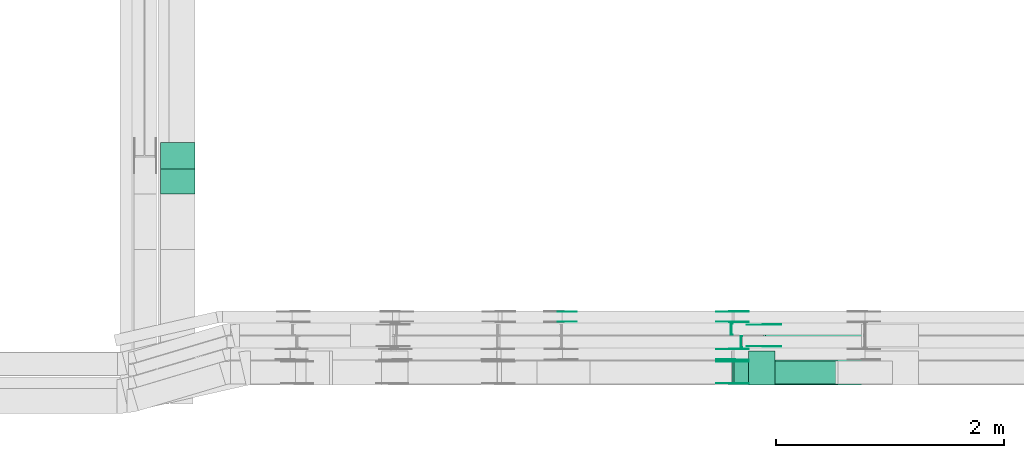
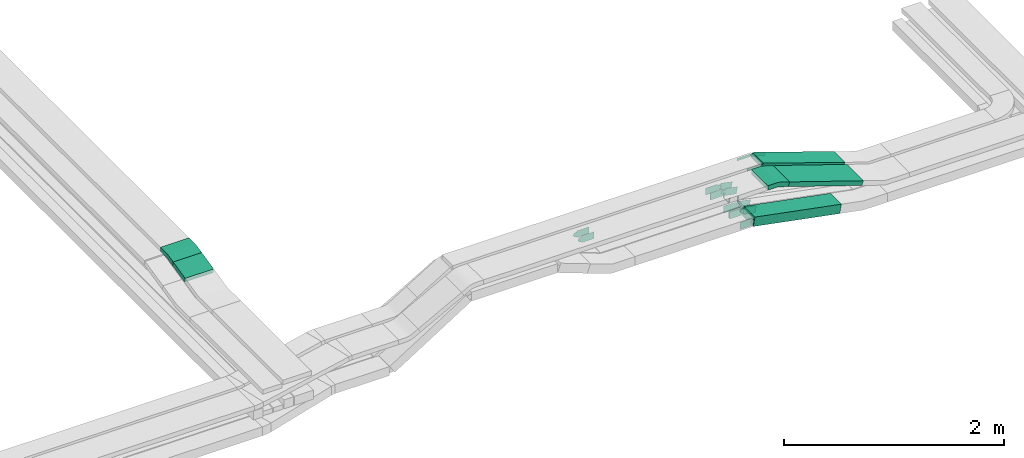
# One storey, part 27 of 31: 22 flow fittings, 4 flow segments.
"""IFC2X3 building model written with IfcOpenShell, lengths in millimetres."""

from ifc_helpers import new_model, entity, si_unit, converted_unit, derived_unit, direction, frame, frame_2d, origin, origin_2d_with_axis, place, context, subcontext, project, spatial, polyline, circle_curve, parameter, trimmed, segment, composite_curve, rectangle, outline, extrude, faceted_brep, source, transform, mapped, material, type_object, type_shapes, element, save


model = new_model("IFC2X3")

# Units and contexts
model_context = context("Model", 3, precision=0.01, world=origin(), true_north=direction((6.12303176911189e-17, 1.0)))
body_context = subcontext(model_context, "Body", "Model", "MODEL_VIEW")
ifc_project = project(units=[si_unit("LENGTHUNIT", "METRE", prefix="MILLI"), si_unit("AREAUNIT", "SQUARE_METRE"), si_unit("VOLUMEUNIT", "CUBIC_METRE"), converted_unit("PLANEANGLEUNIT", "DEGREE", entity("IfcRatioMeasure", 0.0174532925199433), si_unit("PLANEANGLEUNIT", "RADIAN"), dimensions=[0, 0, 0, 0, 0, 0, 0]), si_unit("MASSUNIT", "GRAM", prefix="KILO"), derived_unit("MASSDENSITYUNIT", [(si_unit("MASSUNIT", "GRAM", prefix="KILO"), 1), (si_unit("LENGTHUNIT", "METRE"), -3)]), derived_unit("MOMENTOFINERTIAUNIT", [(si_unit("LENGTHUNIT", "METRE"), 4)]), si_unit("TIMEUNIT", "SECOND"), si_unit("FREQUENCYUNIT", "HERTZ"), si_unit("THERMODYNAMICTEMPERATUREUNIT", "DEGREE_CELSIUS"), derived_unit("THERMALTRANSMITTANCEUNIT", [(si_unit("MASSUNIT", "GRAM", prefix="KILO"), 1), (si_unit("THERMODYNAMICTEMPERATUREUNIT", "KELVIN"), -1), (si_unit("TIMEUNIT", "SECOND"), -3)]), derived_unit("VOLUMETRICFLOWRATEUNIT", [(si_unit("LENGTHUNIT", "METRE"), 3), (si_unit("TIMEUNIT", "SECOND"), -1)]), derived_unit("MASSFLOWRATEUNIT", [(si_unit("MASSUNIT", "GRAM", prefix="KILO"), 1), (si_unit("TIMEUNIT", "SECOND"), -1)]), derived_unit("ROTATIONALFREQUENCYUNIT", [(si_unit("TIMEUNIT", "SECOND"), -1)]), si_unit("ELECTRICCURRENTUNIT", "AMPERE"), si_unit("ELECTRICVOLTAGEUNIT", "VOLT"), si_unit("POWERUNIT", "WATT"), si_unit("FORCEUNIT", "NEWTON", prefix="KILO"), si_unit("ILLUMINANCEUNIT", "LUX"), si_unit("LUMINOUSFLUXUNIT", "LUMEN"), si_unit("LUMINOUSINTENSITYUNIT", "CANDELA"), derived_unit("USERDEFINED", [(si_unit("MASSUNIT", "GRAM", prefix="KILO"), -1), (si_unit("LENGTHUNIT", "METRE"), -2), (si_unit("TIMEUNIT", "SECOND"), 3), (si_unit("LUMINOUSFLUXUNIT", "LUMEN"), 1)]), derived_unit("LINEARVELOCITYUNIT", [(si_unit("LENGTHUNIT", "METRE"), 1), (si_unit("TIMEUNIT", "SECOND"), -1)]), si_unit("PRESSUREUNIT", "PASCAL"), derived_unit("USERDEFINED", [(si_unit("LENGTHUNIT", "METRE"), -2), (si_unit("MASSUNIT", "GRAM", prefix="KILO"), 1), (si_unit("TIMEUNIT", "SECOND"), -2)]), derived_unit("LINEARFORCEUNIT", [(si_unit("MASSUNIT", "GRAM", prefix="KILO"), 1), (si_unit("LENGTHUNIT", "METRE"), 1), (si_unit("TIMEUNIT", "SECOND"), -2), (si_unit("LENGTHUNIT", "METRE"), -1)]), derived_unit("PLANARFORCEUNIT", [(si_unit("MASSUNIT", "GRAM", prefix="KILO"), 1), (si_unit("LENGTHUNIT", "METRE"), 1), (si_unit("TIMEUNIT", "SECOND"), -2), (si_unit("LENGTHUNIT", "METRE"), -2)])], contexts=[model_context])

# Site, building, storey
site_placement = place(None, frame((0.0, -0.00077364408347762, 0.0)))
site = spatial("IfcSite", under=ifc_project, at=site_placement, CompositionType="ELEMENT")
building_placement = place(site_placement, origin())
building = spatial("IfcBuilding", under=site, at=building_placement, CompositionType="ELEMENT")
storey_placement = place(building_placement, frame((0.0, 0.0, 15900.0)))
storey = spatial("IfcBuildingStorey", under=building, at=storey_placement, CompositionType="ELEMENT", Elevation=15900.0)

# Flow segments
cable_carrier_segment_type = type_object("IfcCableCarrierSegmentType", PredefinedType="CABLETRAYSEGMENT")
flow_segment_1_placement = place(storey_placement, frame((60480.8175590596, 10142.2365684485, 2935.93007796764)))
element("IfcFlowSegment", 1, at=flow_segment_1_placement, inside=storey, type_object=cable_carrier_segment_type, context=body_context, shape_type="SweptSolid", body=[
    extrude(rectangle(XDim=49.999999999999, YDim=224.379471632193, at=frame_2d((1.05870867628255e-12, -2.39808173319034e-13), x_axis=(0.0, 1.0))), frame((0.0, 114.940729492026, 49.171043083638), z_axis=(1.0, 0.0, 0.0), x_axis=(0.0, 0.975283876332618, 0.220955562422907)), (0.0, 0.0, 1.0), 300.000000000001),
])
flow_segment_2_placement = place(storey_placement, frame((65492.2607911448, 8474.9658623949, 2643.47474906301)))
element("IfcFlowSegment", 2, at=flow_segment_2_placement, inside=storey, type_object=cable_carrier_segment_type, context=body_context, shape_type="SweptSolid", body=[
    extrude(rectangle(XDim=100.000000000002, YDim=200.0, at=origin_2d_with_axis()), frame((9.43480331321848, 100.0, 223.846520359347), z_axis=(0.982035536310349, 0.0, -0.188696066264366), x_axis=(0.188696066264366, 0.0, 0.982035536310349)), (0.0, 0.0, 1.0), 926.06458101267),
])
flow_segment_3_placement = place(storey_placement, frame((65854.0496090331, 8465.14842319196, 2881.95394727716)))
element("IfcFlowSegment", 3, at=flow_segment_3_placement, inside=storey, type_object=cable_carrier_segment_type, context=body_context, shape_type="SweptSolid", body=[
    extrude(rectangle(XDim=50.0000000000008, YDim=300.000000000001, at=origin_2d_with_axis()), frame((7.9003283393371, 150.0, 282.030022045849), z_axis=(0.948754815223127, 0.0, -0.316013133573479), x_axis=(0.316013133573479, 0.0, 0.948754815223127)), (0.0, 0.0, 1.0), 817.406380375089),
])
flow_segment_4_placement = place(storey_placement, frame((65771.2685007045, 8800.14842319195, 2883.34658837114)))
element("IfcFlowSegment", 4, at=flow_segment_4_placement, inside=storey, type_object=cable_carrier_segment_type, context=body_context, shape_type="SweptSolid", body=[
    extrude(rectangle(XDim=50.000000000002, YDim=200.0, at=origin_2d_with_axis()), frame((8.02889653029172, 100.0, 314.796019997539), z_axis=(0.947026352753396, 0.0, -0.321155861211656), x_axis=(0.321155861211656, 0.0, 0.947026352753396)), (0.0, 0.0, 1.0), 906.476874126866),
])

# Flow fittings
ifc_material_1 = material(Name="G")
cable_carrier_fitting_type_1 = type_object("IfcCableCarrierFittingType", PredefinedType="NOTDEFINED", material=ifc_material_1)
shared_shape_1 = source(origin(), body_context, "Body", "SweptSolid", [
    extrude(outline(composite_curve([segment(trimmed(circle_curve(frame_2d((-44.5901162790698, 0.0), x_axis=(1.0, 0.0)), 12.5), [parameter(90.0000000000007)], [parameter(270.0)], True, "PARAMETER"), True, "CONTINUOUS"), segment(polyline([(-44.5901162790697, -12.5), (-33.0901162790698, -12.5)]), True, "CONTINUOUS"), segment(polyline([(-33.0901162790698, -12.5), (-31.2296511627907, -14.5)]), True, "CONTINUOUS"), segment(polyline([(-31.2296511627907, -14.5), (108.90988372093, -14.5)]), True, "CONTINUOUS"), segment(polyline([(108.90988372093, -14.5), (108.90988372093, 14.5)]), True, "CONTINUOUS"), segment(polyline([(108.90988372093, 14.5), (-31.2296511627907, 14.5)]), True, "CONTINUOUS"), segment(polyline([(-31.2296511627907, 14.5), (-33.0901162790698, 12.5)]), True, "CONTINUOUS"), segment(polyline([(-33.0901162790698, 12.5), (-44.5901162790699, 12.5)]), True, "CONTINUOUS")], self_intersect=False)), frame((44.5901162790698, 0.0, 0.0), z_axis=(0.0, 0.0, -1.0), x_axis=(1.0, 0.0, 0.0)), (0.0, 0.0, -1.0), 2.0),
])
type_shapes(cable_carrier_fitting_type_1, [shared_shape_1])
flow_fitting_1_placement = place(storey_placement, frame((65773.8203095191, 8995.60842320211, 3200.0), z_axis=(0.0, 1.0, 0.0), x_axis=(0.947026352753384, 0.0, -0.321155861211693)))
element("IfcFlowFitting", 5, at=flow_fitting_1_placement, inside=storey, type_object=cable_carrier_fitting_type_1, material=ifc_material_1, context=body_context, shape_type="MappedRepresentation", body=[
    mapped(shared_shape_1, transform((0.0, 0.0, 0.0), scale=1.0)),
])
cable_carrier_fitting_type_2 = type_object("IfcCableCarrierFittingType", PredefinedType="NOTDEFINED", material=ifc_material_1)
shared_shape_2 = source(origin(), body_context, "Body", "SweptSolid", [
    extrude(outline(composite_curve([segment(trimmed(circle_curve(frame_2d((-44.5901162790697, 0.0), x_axis=(1.0, 0.0)), 12.5), [parameter(90.0000000000007)], [parameter(270.0)], True, "PARAMETER"), True, "CONTINUOUS"), segment(polyline([(-44.5901162790697, -12.5), (-33.0901162790697, -12.5)]), True, "CONTINUOUS"), segment(polyline([(-33.0901162790697, -12.5), (-31.2296511627907, -14.5)]), True, "CONTINUOUS"), segment(polyline([(-31.2296511627907, -14.5), (108.90988372093, -14.5)]), True, "CONTINUOUS"), segment(polyline([(108.90988372093, -14.5), (108.90988372093, 14.5)]), True, "CONTINUOUS"), segment(polyline([(108.90988372093, 14.5), (-31.2296511627907, 14.5)]), True, "CONTINUOUS"), segment(polyline([(-31.2296511627907, 14.5), (-33.0901162790698, 12.5)]), True, "CONTINUOUS"), segment(polyline([(-33.0901162790698, 12.5), (-44.5901162790699, 12.5)]), True, "CONTINUOUS")], self_intersect=False)), frame((44.5901162790697, 0.0, 0.0)), (0.0, 0.0, 1.0), 2.0),
])
type_shapes(cable_carrier_fitting_type_2, [shared_shape_2])
flow_fitting_2_placement = place(storey_placement, frame((65773.8203095191, 8804.68842318179, 3200.0), z_axis=(0.0, -1.0, 0.0), x_axis=(0.947026352753384, 0.0, -0.321155861211693)))
element("IfcFlowFitting", 6, at=flow_fitting_2_placement, inside=storey, type_object=cable_carrier_fitting_type_2, material=ifc_material_1, context=body_context, shape_type="MappedRepresentation", body=[
    mapped(shared_shape_2, transform((0.0, 0.0, 0.0), scale=1.0)),
])
cable_carrier_fitting_type_3 = type_object("IfcCableCarrierFittingType", PredefinedType="NOTDEFINED", material=ifc_material_1)
shared_shape_3 = source(origin(), body_context, "Body", "SweptSolid", [
    extrude(outline(composite_curve([segment(trimmed(circle_curve(frame_2d((-44.5901162790698, 0.0), x_axis=(1.0, 0.0)), 12.5), [parameter(90.0000000000007)], [parameter(270.0)], True, "PARAMETER"), True, "CONTINUOUS"), segment(polyline([(-44.5901162790697, -12.5), (-33.0901162790698, -12.5)]), True, "CONTINUOUS"), segment(polyline([(-33.0901162790698, -12.5), (-31.2296511627907, -14.5)]), True, "CONTINUOUS"), segment(polyline([(-31.2296511627907, -14.5), (108.90988372093, -14.5)]), True, "CONTINUOUS"), segment(polyline([(108.90988372093, -14.5), (108.90988372093, 14.5)]), True, "CONTINUOUS"), segment(polyline([(108.90988372093, 14.5), (-31.2296511627907, 14.5)]), True, "CONTINUOUS"), segment(polyline([(-31.2296511627907, 14.5), (-33.0901162790698, 12.5)]), True, "CONTINUOUS"), segment(polyline([(-33.0901162790698, 12.5), (-44.5901162790699, 12.5)]), True, "CONTINUOUS")], self_intersect=False)), frame((44.5901162790698, 0.0, 0.0), z_axis=(0.0, 0.0, -1.0), x_axis=(1.0, 0.0, 0.0)), (0.0, 0.0, -1.0), 2.0),
])
type_shapes(cable_carrier_fitting_type_3, [shared_shape_3])
flow_fitting_3_placement = place(storey_placement, frame((65773.8203095191, 8806.68842318179, 3200.0), z_axis=(0.0, -1.0, 0.0), x_axis=(-1.0, 0.0, 0.0)))
element("IfcFlowFitting", 7, at=flow_fitting_3_placement, inside=storey, type_object=cable_carrier_fitting_type_3, material=ifc_material_1, context=body_context, shape_type="MappedRepresentation", body=[
    mapped(shared_shape_3, transform((0.0, 0.0, 0.0), scale=1.0)),
])
cable_carrier_fitting_type_4 = type_object("IfcCableCarrierFittingType", PredefinedType="NOTDEFINED", material=ifc_material_1)
shared_shape_4 = source(origin(), body_context, "Body", "SweptSolid", [
    extrude(outline(composite_curve([segment(trimmed(circle_curve(frame_2d((-44.5901162790697, 0.0), x_axis=(1.0, 0.0)), 12.5), [parameter(90.0000000000007)], [parameter(270.0)], True, "PARAMETER"), True, "CONTINUOUS"), segment(polyline([(-44.5901162790697, -12.5), (-33.0901162790697, -12.5)]), True, "CONTINUOUS"), segment(polyline([(-33.0901162790697, -12.5), (-31.2296511627907, -14.5)]), True, "CONTINUOUS"), segment(polyline([(-31.2296511627907, -14.5), (108.90988372093, -14.5)]), True, "CONTINUOUS"), segment(polyline([(108.90988372093, -14.5), (108.90988372093, 14.5)]), True, "CONTINUOUS"), segment(polyline([(108.90988372093, 14.5), (-31.2296511627907, 14.5)]), True, "CONTINUOUS"), segment(polyline([(-31.2296511627907, 14.5), (-33.0901162790698, 12.5)]), True, "CONTINUOUS"), segment(polyline([(-33.0901162790698, 12.5), (-44.5901162790699, 12.5)]), True, "CONTINUOUS")], self_intersect=False)), frame((44.5901162790697, 0.0, 0.0)), (0.0, 0.0, 1.0), 2.0),
])
type_shapes(cable_carrier_fitting_type_4, [shared_shape_4])
flow_fitting_4_placement = place(storey_placement, frame((65773.8203095191, 8993.60842320211, 3200.0), z_axis=(0.0, 1.0, 0.0), x_axis=(-1.0, 0.0, 0.0)))
element("IfcFlowFitting", 8, at=flow_fitting_4_placement, inside=storey, type_object=cable_carrier_fitting_type_4, material=ifc_material_1, context=body_context, shape_type="MappedRepresentation", body=[
    mapped(shared_shape_4, transform((0.0, 0.0, 0.0), scale=1.0)),
])
cable_carrier_fitting_type_5 = type_object("IfcCableCarrierFittingType", PredefinedType="NOTDEFINED", material=ifc_material_1)
shared_shape_5 = source(origin(), body_context, "Body", "SweptSolid", [
    extrude(outline(composite_curve([segment(trimmed(circle_curve(frame_2d((-41.4651162790697, 0.0), x_axis=(1.0, 0.0)), 25.0), [parameter(90.0000000000007)], [parameter(270.0)], True, "PARAMETER"), True, "CONTINUOUS"), segment(polyline([(-41.4651162790697, -25.0), (-29.9651162790697, -25.0)]), True, "CONTINUOUS"), segment(polyline([(-29.9651162790697, -25.0), (-28.1046511627907, -38.5)]), True, "CONTINUOUS"), segment(polyline([(-28.1046511627907, -38.5), (99.5348837209303, -38.5)]), True, "CONTINUOUS"), segment(polyline([(99.5348837209303, -38.5), (99.5348837209303, 38.5)]), True, "CONTINUOUS"), segment(polyline([(99.5348837209303, 38.5), (-28.1046511627907, 38.5)]), True, "CONTINUOUS"), segment(polyline([(-28.1046511627907, 38.5), (-29.9651162790697, 25.0)]), True, "CONTINUOUS"), segment(polyline([(-29.9651162790697, 25.0), (-41.46511627907, 25.0)]), True, "CONTINUOUS")], self_intersect=False)), frame((41.4651162790697, 0.0, 0.0), z_axis=(0.0, 0.0, -1.0), x_axis=(1.0, 0.0, 0.0)), (0.0, 0.0, -1.0), 2.0),
])
type_shapes(cable_carrier_fitting_type_5, [shared_shape_5])
for number, where, z_axis, x_axis in (
    (9, (65495.6649425276, 8780.42586240513, 2868.48004652785), (0.0, 1.0, 0.0), (0.982035536310358, 0.0, -0.188696066264316)),
    (10, (65495.6649425276, 9110.42586240521, 2868.48004652786), (0.0, 1.0, 0.0), (0.982035536310358, 0.0, -0.188696066264316)),
    (11, (65495.6649425276, 8670.42586240506, 2868.48004652788), (0.0, 1.0, 0.0), (0.982035536310354, 0.0, -0.18869606626434)),
):
    element("IfcFlowFitting", number, at=place(storey_placement, frame(where, z_axis=z_axis, x_axis=x_axis)), inside=storey, type_object=cable_carrier_fitting_type_5, material=ifc_material_1, context=body_context, shape_type="MappedRepresentation", body=[
        mapped(shared_shape_5, transform((0.0, 0.0, 0.0), scale=1.0)),
    ])
cable_carrier_fitting_type_6 = type_object("IfcCableCarrierFittingType", PredefinedType="NOTDEFINED", material=ifc_material_1)
shared_shape_6 = source(origin(), body_context, "Body", "SweptSolid", [
    extrude(outline(composite_curve([segment(trimmed(circle_curve(frame_2d((-41.4651162790697, 0.0), x_axis=(1.0, 0.0)), 25.0), [parameter(90.0000000000007)], [parameter(270.0)], True, "PARAMETER"), True, "CONTINUOUS"), segment(polyline([(-41.4651162790697, -25.0), (-29.9651162790697, -25.0)]), True, "CONTINUOUS"), segment(polyline([(-29.9651162790697, -25.0), (-28.1046511627907, -38.5)]), True, "CONTINUOUS"), segment(polyline([(-28.1046511627907, -38.5), (99.5348837209303, -38.5)]), True, "CONTINUOUS"), segment(polyline([(99.5348837209303, -38.5), (99.5348837209303, 38.5)]), True, "CONTINUOUS"), segment(polyline([(99.5348837209303, 38.5), (-28.1046511627907, 38.5)]), True, "CONTINUOUS"), segment(polyline([(-28.1046511627907, 38.5), (-29.9651162790697, 25.0)]), True, "CONTINUOUS"), segment(polyline([(-29.9651162790697, 25.0), (-41.46511627907, 25.0)]), True, "CONTINUOUS")], self_intersect=False)), frame((41.4651162790697, 0.0, 0.0)), (0.0, 0.0, 1.0), 2.0),
])
type_shapes(cable_carrier_fitting_type_6, [shared_shape_6])
for number, where, z_axis, x_axis in (
    (12, (65495.6649425276, 8689.50586238482, 2868.48004652786), (0.0, -1.0, 0.0), (0.982035536310358, 0.0, -0.188696066264316)),
    (13, (65495.6649425276, 9019.5058623849, 2868.48004652786), (0.0, -1.0, 0.0), (0.982035536310358, 0.0, -0.188696066264316)),
    (14, (65495.6649425276, 8479.50586238474, 2868.48004652788), (0.0, -1.0, 0.0), (0.982035536310354, 0.0, -0.18869606626434)),
):
    element("IfcFlowFitting", number, at=place(storey_placement, frame(where, z_axis=z_axis, x_axis=x_axis)), inside=storey, type_object=cable_carrier_fitting_type_6, material=ifc_material_1, context=body_context, shape_type="MappedRepresentation", body=[
        mapped(shared_shape_6, transform((0.0, 0.0, 0.0), scale=1.0)),
    ])
cable_carrier_fitting_type_7 = type_object("IfcCableCarrierFittingType", PredefinedType="NOTDEFINED", material=ifc_material_1)
shared_shape_7 = source(origin(), body_context, "Body", "SweptSolid", [
    extrude(outline(composite_curve([segment(trimmed(circle_curve(frame_2d((-41.4651162790697, 0.0), x_axis=(1.0, 0.0)), 25.0), [parameter(90.0000000000007)], [parameter(270.0)], True, "PARAMETER"), True, "CONTINUOUS"), segment(polyline([(-41.4651162790697, -25.0), (-29.9651162790697, -25.0)]), True, "CONTINUOUS"), segment(polyline([(-29.9651162790697, -25.0), (-28.1046511627907, -38.5)]), True, "CONTINUOUS"), segment(polyline([(-28.1046511627907, -38.5), (99.5348837209303, -38.5)]), True, "CONTINUOUS"), segment(polyline([(99.5348837209303, -38.5), (99.5348837209303, 38.5)]), True, "CONTINUOUS"), segment(polyline([(99.5348837209303, 38.5), (-28.1046511627907, 38.5)]), True, "CONTINUOUS"), segment(polyline([(-28.1046511627907, 38.5), (-29.9651162790697, 25.0)]), True, "CONTINUOUS"), segment(polyline([(-29.9651162790697, 25.0), (-41.46511627907, 25.0)]), True, "CONTINUOUS")], self_intersect=False)), frame((41.4651162790697, 0.0, 0.0), z_axis=(0.0, 0.0, -1.0), x_axis=(1.0, 0.0, 0.0)), (0.0, 0.0, -1.0), 2.0),
])
type_shapes(cable_carrier_fitting_type_7, [shared_shape_7])
for number, where, z_axis, x_axis in (
    (15, (65495.6649425276, 8691.50586238482, 2868.48004652785), (0.0, -1.0, 0.0), (-1.0, 0.0, 0.0)),
    (16, (65495.6649425276, 9021.50586238489, 2868.48004652785), (0.0, -1.0, 0.0), (-1.0, 0.0, 0.0)),
    (17, (63990.7514643752, 9021.50586238489, 2868.4800465278), (0.0, -1.0, 0.0), (1.0, 0.0, 0.0)),
    (18, (65495.6649425277, 8481.50586238474, 2868.48004652787), (0.0, -1.0, 0.0), (-1.0, 0.0, 0.0)),
):
    element("IfcFlowFitting", number, at=place(storey_placement, frame(where, z_axis=z_axis, x_axis=x_axis)), inside=storey, type_object=cable_carrier_fitting_type_7, material=ifc_material_1, context=body_context, shape_type="MappedRepresentation", body=[
        mapped(shared_shape_7, transform((0.0, 0.0, 0.0), scale=1.0)),
    ])
cable_carrier_fitting_type_8 = type_object("IfcCableCarrierFittingType", PredefinedType="NOTDEFINED", material=ifc_material_1)
shared_shape_8 = source(origin(), body_context, "Body", "SweptSolid", [
    extrude(outline(composite_curve([segment(trimmed(circle_curve(frame_2d((-41.4651162790697, 0.0), x_axis=(1.0, 0.0)), 25.0), [parameter(90.0000000000007)], [parameter(270.0)], True, "PARAMETER"), True, "CONTINUOUS"), segment(polyline([(-41.4651162790697, -25.0), (-29.9651162790697, -25.0)]), True, "CONTINUOUS"), segment(polyline([(-29.9651162790697, -25.0), (-28.1046511627907, -38.5)]), True, "CONTINUOUS"), segment(polyline([(-28.1046511627907, -38.5), (99.5348837209303, -38.5)]), True, "CONTINUOUS"), segment(polyline([(99.5348837209303, -38.5), (99.5348837209303, 38.5)]), True, "CONTINUOUS"), segment(polyline([(99.5348837209303, 38.5), (-28.1046511627907, 38.5)]), True, "CONTINUOUS"), segment(polyline([(-28.1046511627907, 38.5), (-29.9651162790697, 25.0)]), True, "CONTINUOUS"), segment(polyline([(-29.9651162790697, 25.0), (-41.46511627907, 25.0)]), True, "CONTINUOUS")], self_intersect=False)), frame((41.4651162790697, 0.0, 0.0)), (0.0, 0.0, 1.0), 2.0),
])
type_shapes(cable_carrier_fitting_type_8, [shared_shape_8])
for number, where, z_axis, x_axis in (
    (19, (65495.6649425276, 8778.42586240513, 2868.48004652785), (0.0, 1.0, 0.0), (-1.0, 0.0, 0.0)),
    (20, (65495.6649425276, 9108.42586240521, 2868.48004652785), (0.0, 1.0, 0.0), (-1.0, 0.0, 0.0)),
    (21, (63990.7514643752, 9108.42586240521, 2868.4800465278), (0.0, 1.0, 0.0), (1.0, 0.0, 0.0)),
    (22, (65495.6649425277, 8668.42586240506, 2868.48004652787), (0.0, 1.0, 0.0), (-1.0, 0.0, 0.0)),
):
    element("IfcFlowFitting", number, at=place(storey_placement, frame(where, z_axis=z_axis, x_axis=x_axis)), inside=storey, type_object=cable_carrier_fitting_type_8, material=ifc_material_1, context=body_context, shape_type="MappedRepresentation", body=[
        mapped(shared_shape_8, transform((0.0, 0.0, 0.0), scale=1.0)),
    ])
ifc_material_2 = material()
cable_carrier_fitting_type_9 = type_object("IfcCableCarrierFittingType", Name="470_DKC_S5_CD 90 external vertical angle:-", PredefinedType="NOTDEFINED", material=ifc_material_2)
shared_shape_9 = source(origin(), body_context, "Body", "SweptSolid", [
    extrude(outline(composite_curve([segment(polyline([(-112.826209803892, -32.2970232946341), (-17.6406795657118, -32.2970232946341)]), True, "CONTINUOUS"), segment(trimmed(circle_curve(frame_2d((-17.6406795657121, 157.702976705365), x_axis=(0.0, -1.0)), 189.999999999999), [parameter(0.0)], [parameter(12.7651639618241)], True, "PARAMETER"), True, "CONTINUOUS"), segment(polyline([(24.3408772946406, -27.6009597978314), (117.173790196108, -6.56918742953162)]), True, "CONTINUOUS"), segment(polyline([(117.173790196108, -6.56918742953164), (106.126012074963, 42.1950063870995)]), True, "CONTINUOUS"), segment(polyline([(106.126012074963, 42.1950063870995), (13.293099173495, 21.1632340187997)]), True, "CONTINUOUS"), segment(trimmed(circle_curve(frame_2d((-17.6406795657121, 157.702976705365), x_axis=(0.0, -1.0)), 139.999999999999), [parameter(0.0)], [parameter(12.7651639618241)], True, "PARAMETER"), False, "CONTINUOUS"), segment(polyline([(-17.6406795657118, 17.7029767053662), (-112.826209803892, 17.7029767053662)]), True, "CONTINUOUS"), segment(polyline([(-112.826209803892, 17.7029767053662), (-112.826209803892, -32.2970232946341)]), True, "CONTINUOUS")], self_intersect=False)), frame((-0.816246163591839, 7.29702329462689, -150.0)), (0.0, 0.0, 1.0), 300.0),
])
type_shapes(cable_carrier_fitting_type_9, [shared_shape_9])
flow_fitting_5_placement = place(storey_placement, frame((60630.8175590596, 10477.4277933439, 3035.0), z_axis=(1.0, 0.0, 0.0), x_axis=(0.0, -1.0, 0.0)))
element("IfcFlowFitting", 23, at=flow_fitting_5_placement, inside=storey, type_object=cable_carrier_fitting_type_9, material=ifc_material_2, Name="470_DKC_S5_CD 90 external vertical angle:-", ObjectType="470_DKC_S5_CD 90 external vertical angle:-", context=body_context, shape_type="MappedRepresentation", body=[
    mapped(shared_shape_9, transform((0.0, 0.0, 0.0), scale=1.0)),
])
cable_carrier_fitting_type_10 = type_object("IfcCableCarrierFittingType", Name="470_DKC_S5_CD 90 external vertical angle:-", PredefinedType="NOTDEFINED", material=ifc_material_2)
shared_shape_10 = source(origin(), body_context, "Body", "SweptSolid", [
    extrude(outline(composite_curve([segment(polyline([(-112.167152341943, -36.1178715413069), (-24.9537670081974, -36.1178715413069)]), True, "CONTINUOUS"), segment(trimmed(circle_curve(frame_2d((-24.9537670081976, 153.882128458692), x_axis=(0.0, -1.0)), 189.999999999999), [parameter(0.0)], [parameter(18.4219865734393)], True, "PARAMETER"), True, "CONTINUOUS"), segment(polyline([(35.0887283707547, -26.381286433704), (117.832847658057, 1.17928875516027)]), True, "CONTINUOUS"), segment(polyline([(117.832847658057, 1.17928875516027), (102.032190979385, 48.6170295163176)]), True, "CONTINUOUS"), segment(polyline([(102.032190979385, 48.6170295163176), (19.2880716920829, 21.0564543274534)]), True, "CONTINUOUS"), segment(trimmed(circle_curve(frame_2d((-24.9537670081976, 153.882128458692), x_axis=(0.0, -1.0)), 139.999999999999), [parameter(0.0)], [parameter(18.4219865734393)], True, "PARAMETER"), False, "CONTINUOUS"), segment(polyline([(-24.9537670081974, 13.8821284586934), (-112.167152341943, 13.8821284586934)]), True, "CONTINUOUS"), segment(polyline([(-112.167152341943, 13.8821284586934), (-112.167152341943, -36.1178715413069)]), True, "CONTINUOUS")], self_intersect=False)), frame((-1.80289146534615, 11.1178715412997, -150.0)), (0.0, 0.0, 1.0), 300.0),
])
type_shapes(cable_carrier_fitting_type_10, [shared_shape_10])
flow_fitting_6_placement = place(storey_placement, frame((65753.8203095191, 8615.14842319197, 3200.0), z_axis=(0.0, 1.0, 0.0), x_axis=(1.0, 0.0, 0.0)))
element("IfcFlowFitting", 24, at=flow_fitting_6_placement, inside=storey, type_object=cable_carrier_fitting_type_10, material=ifc_material_2, Name="470_DKC_S5_CD 90 external vertical angle:-", ObjectType="470_DKC_S5_CD 90 external vertical angle:-", context=body_context, shape_type="MappedRepresentation", body=[
    mapped(shared_shape_10, transform((0.0, 0.0, 0.0), scale=1.0)),
])
cable_carrier_fitting_type_11 = type_object("IfcCableCarrierFittingType", PredefinedType="NOTDEFINED", material=ifc_material_2)
shared_shape_11 = source(origin(), body_context, "Body", "Brep", [
    faceted_brep([(-5.06072137132877, 25.0, 50.0), (-5.06072137132877, 25.0, -50.0), (-5.06072137132893, -25.0, -50.0), (-5.06072137132893, -25.0, -47.4600000101565), (-5.06072137132878, 22.46000001016, -47.4600000101565), (-5.06072137132878, 22.46000001016, 47.4600000101635), (-5.06072137132893, -25.0, 47.4600000101635), (-5.06072137132893, -25.0, 50.0), (-0.051318131770118, 25.5070238806404, 50.0), (9.96748834734716, -23.478928358078, 50.0), (9.96748834734716, -23.478928358078, 47.4600000101635), (0.45763723533322, 23.0185375168674, 47.4600000101635), (0.457637235333217, 23.0185375168674, -47.4600000101565), (9.96748834734716, -23.478928358078, -47.4600000101565), (9.96748834734717, -23.478928358078, -50.0), (-0.051318131770118, 25.5070238806404, -50.0), (-2.53036068566412, 25.0, 50.0), (-2.53036068566416, 25.0, -50.0), (2.53036068566507, -25.0, -50.0), (2.53036068566507, -25.0, -47.4600000101565), (-2.27327604102898, 22.46000001016, -47.4600000101565), (-2.27327604102898, 22.46000001016, 47.4600000101635), (2.53036068566507, -25.0, 47.4600000101635), (2.53036068566507, -25.0, 50.0)], [[[0, 1, 2, 3, 4, 5, 6, 7]], [[8, 9, 10, 11, 12, 13, 14, 15]], [[1, 0, 16, 17]], [[2, 1, 17, 15, 14, 18]], [[3, 2, 18, 19]], [[4, 3, 19, 13, 12, 20]], [[5, 4, 20, 21]], [[6, 5, 21, 11, 10, 22]], [[7, 6, 22, 23]], [[0, 7, 23, 9, 8, 16]], [[17, 16, 8, 15]], [[19, 18, 14, 13]], [[21, 20, 12, 11]], [[23, 22, 10, 9]]]),
])
type_shapes(cable_carrier_fitting_type_11, [shared_shape_11])
flow_fitting_7_placement = place(storey_placement, frame((65573.1498817787, 8844.96586239506, 2843.48004652784), z_axis=(0.0, 1.0, 0.0), x_axis=(1.0, 0.0, 0.0)))
element("IfcFlowFitting", 25, at=flow_fitting_7_placement, inside=storey, type_object=cable_carrier_fitting_type_11, material=ifc_material_2, context=body_context, shape_type="MappedRepresentation", body=[
    mapped(shared_shape_11, transform((0.0, 0.0, 0.0), scale=1.0)),
])
cable_carrier_fitting_type_12 = type_object("IfcCableCarrierFittingType", PredefinedType="NOTDEFINED", material=ifc_material_2)
shared_shape_12 = source(origin(), body_context, "Body", "Brep", [
    faceted_brep([(-4.70112561692858, 25.0, 50.0), (-4.70112561692858, 25.0, -50.0), (-4.70112561692874, -25.0, -50.0), (-4.70112561692874, -25.0, -47.4600000101565), (-4.70112561692858, 22.46000001016, -47.4600000101565), (-4.70112561692858, 22.46000001016, 47.4600000101635), (-4.70112561692874, -25.0, 47.4600000101635), (-4.70112561692874, -25.0, 50.0), (-0.0411948727333111, 25.4381383958926, 50.0), (9.27866661565716, -23.6855848123214, 50.0), (9.27866661565716, -23.6855848123214, 47.4600000101635), (0.432254088983129, 22.9426532668972, 47.4600000101635), (0.43225408898313, 22.9426532668972, -47.4600000101565), (9.27866661565716, -23.6855848123214, -47.4600000101565), (9.27866661565716, -23.6855848123214, -50.0), (-0.0411948727333111, 25.4381383958926, -50.0), (-2.35056280846401, 25.0, 50.0), (-2.35056280846405, 25.0, -50.0), (2.35056280846497, -25.0, -50.0), (2.35056280846497, -25.0, -47.4600000101565), (-2.11174562807933, 22.46000001016, -47.4600000101565), (-2.11174562807933, 22.46000001016, 47.4600000101635), (2.35056280846497, -25.0, 47.4600000101635), (2.35056280846497, -25.0, 50.0)], [[[0, 1, 2, 3, 4, 5, 6, 7]], [[8, 9, 10, 11, 12, 13, 14, 15]], [[1, 0, 16, 17]], [[2, 1, 17, 15, 14, 18]], [[3, 2, 18, 19]], [[4, 3, 19, 13, 12, 20]], [[5, 4, 20, 21]], [[6, 5, 21, 11, 10, 22]], [[7, 6, 22, 23]], [[0, 7, 23, 9, 8, 16]], [[17, 16, 8, 15]], [[19, 18, 14, 13]], [[21, 20, 12, 11]], [[23, 22, 10, 9]]]),
])
type_shapes(cable_carrier_fitting_type_12, [shared_shape_12])
flow_fitting_8_placement = place(storey_placement, frame((65488.2333471847, 8954.96586239505, 2843.48004652784), z_axis=(0.0, 1.0, 0.0), x_axis=(1.0, 0.0, 0.0)))
element("IfcFlowFitting", 26, at=flow_fitting_8_placement, inside=storey, type_object=cable_carrier_fitting_type_12, material=ifc_material_2, context=body_context, shape_type="MappedRepresentation", body=[
    mapped(shared_shape_12, transform((0.0, 0.0, 0.0), scale=1.0)),
])

save(model, "model.ifc")
